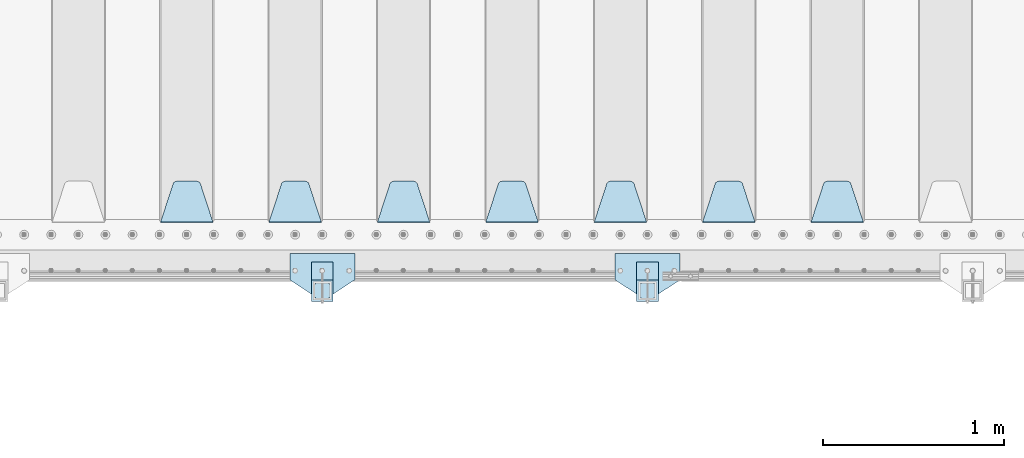
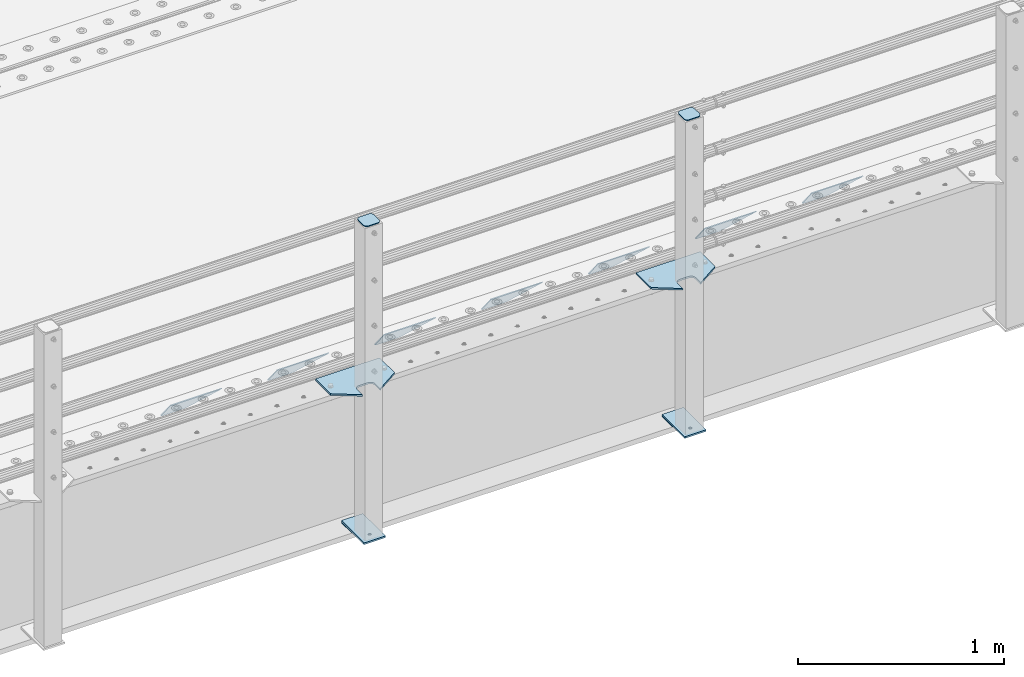
# One storey, part 176 of 208: 15 plates.
"""IFC2X3 building model written with IfcOpenShell, lengths in millimetres."""

from ifc_helpers import new_model, si_unit, frame, origin_with_axes, place, context, subcontext, project, spatial, faceted_brep, material, type_object, element, save


model = new_model("IFC2X3")

# Units and contexts
model_context = context("Model", 3, precision=1e-05, world=origin_with_axes())
body_context = subcontext(model_context, "Body", "Model", "MODEL_VIEW")
ifc_project = project(units=[si_unit("LENGTHUNIT", "METRE", prefix="MILLI"), si_unit("AREAUNIT", "SQUARE_METRE"), si_unit("VOLUMEUNIT", "CUBIC_METRE"), si_unit("MASSUNIT", "GRAM", prefix="KILO"), si_unit("TIMEUNIT", "SECOND"), si_unit("PLANEANGLEUNIT", "RADIAN"), si_unit("SOLIDANGLEUNIT", "STERADIAN"), si_unit("THERMODYNAMICTEMPERATUREUNIT", "DEGREE_CELSIUS"), si_unit("LUMINOUSINTENSITYUNIT", "LUMEN")], contexts=[model_context])

# Site, building, storey
site_placement = place(None, origin_with_axes())
site = spatial("IfcSite", under=ifc_project, at=site_placement, CompositionType="ELEMENT")
building_placement = place(site_placement, origin_with_axes())
building = spatial("IfcBuilding", under=site, at=building_placement, Name="Standard", CompositionType="ELEMENT")
storey_placement = place(building_placement, origin_with_axes())
storey = spatial("IfcBuildingStorey", under=building, at=storey_placement, Name="Undefined", CompositionType="ELEMENT", Elevation=0.0)

# Plates
ifc_material_1 = material(Name="STEEL/S355N")
plate_type_1 = type_object("IfcPlateType", PredefinedType="NOTDEFINED")
plate_1_placement = place(storey_placement, frame((-31705.0, 168.232233047019, -1.76776695296758), z_axis=(0.0, 0.707106781186547, -0.707106781186548), x_axis=(-1.0, 0.0, 0.0)))
element("IfcPlate", 1, at=plate_1_placement, inside=storey, type_object=plate_type_1, material=ifc_material_1, context=body_context, shape_type="Brep", body=[
    faceted_brep([(0.0, -2.5, 0.0), (69.345504679477, -2.5, 300.17173142483), (69.345504679477, 2.5, 300.17173142483), (0.0, 2.5, 0.0), (70.9274061199576, -2.5, 304.897442415399), (70.9274061199576, 2.5, 304.8974424154), (73.3818627772307, -2.5, 309.234538108527), (73.3818627772307, 2.5, 309.234538108527), (76.6187032999551, -2.5, 313.023683126103), (76.6187032999551, 2.5, 313.023683126103), (80.5190132704993, -2.5, 316.125672595371), (80.5190132704993, 2.5, 316.125672595371), (84.9395038596849, -2.5, 318.426546230476), (84.9395038596849, 2.50000000000091, 318.426546230476), (89.7177759439219, -2.5, 319.841774983275), (89.7177759439219, 2.50000000000091, 319.841774983275), (94.678286292652, -2.49999999999909, 320.319366455078), (94.678286292652, 2.5, 320.319366455078), (195.321713707348, -2.49999999999909, 320.319366455078), (195.321713707348, 2.5, 320.319366455078), (200.282224056078, -2.5, 319.841774983275), (200.282224056078, 2.5, 319.841774983274), (205.060496140315, -2.5, 318.426546230475), (205.060496140315, 2.5, 318.426546230475), (209.480986729501, -2.5, 316.125672595371), (209.480986729501, 2.50000000000091, 316.125672595371), (213.381296700045, -2.5, 313.023683126102), (213.381296700045, 2.5, 313.023683126102), (216.618137222769, -2.5, 309.234538108526), (216.618137222769, 2.5, 309.234538108527), (219.072593880042, -2.5, 304.897442415399), (219.072593880042, 2.5, 304.897442415399), (220.654495320523, -2.5, 300.17173142483), (220.654495320523, 2.5, 300.17173142483), (290.0, -2.5, 0.0), (290.0, 2.5, 0.0)], [[[0, 1, 2, 3]], [[1, 4, 5, 2]], [[4, 6, 7, 5]], [[6, 8, 9, 7]], [[8, 10, 11, 9]], [[10, 12, 13, 11]], [[12, 14, 15, 13]], [[14, 16, 17, 15]], [[16, 18, 19, 17]], [[18, 20, 21, 19]], [[20, 22, 23, 21]], [[22, 24, 25, 23]], [[24, 26, 27, 25]], [[26, 28, 29, 27]], [[28, 30, 31, 29]], [[30, 32, 33, 31]], [[32, 34, 35, 33]], [[34, 0, 3, 35]], [[5, 7, 9, 11, 13, 15, 17, 19, 21, 23, 25, 27, 29, 31, 33, 35, 3, 2]], [[34, 32, 30, 28, 26, 24, 22, 20, 18, 16, 14, 12, 10, 8, 6, 4, 1, 0]]]),
])
plate_2_placement = place(storey_placement, frame((-32305.0, 168.232233047023, -1.76776695296758), z_axis=(0.0, 0.707106781186547, -0.707106781186548), x_axis=(-1.0, 0.0, 0.0)))
element("IfcPlate", 2, at=plate_2_placement, inside=storey, type_object=plate_type_1, material=ifc_material_1, context=body_context, shape_type="Brep", body=[
    faceted_brep([(0.0, -2.5, 0.0), (69.345504679477, -2.5, 300.17173142483), (69.345504679477, 2.5, 300.17173142483), (0.0, 2.5, 0.0), (70.9274061199576, -2.5, 304.897442415399), (70.9274061199576, 2.5, 304.8974424154), (73.3818627772307, -2.5, 309.234538108527), (73.3818627772307, 2.5, 309.234538108527), (76.6187032999551, -2.5, 313.023683126103), (76.6187032999551, 2.5, 313.023683126103), (80.5190132704993, -2.5, 316.125672595371), (80.5190132704993, 2.5, 316.125672595371), (84.9395038596849, -2.5, 318.426546230476), (84.9395038596849, 2.50000000000091, 318.426546230476), (89.7177759439219, -2.5, 319.841774983275), (89.7177759439219, 2.50000000000091, 319.841774983275), (94.678286292652, -2.49999999999909, 320.319366455078), (94.678286292652, 2.5, 320.319366455078), (195.321713707348, -2.49999999999909, 320.319366455078), (195.321713707348, 2.5, 320.319366455078), (200.282224056078, -2.5, 319.841774983275), (200.282224056078, 2.5, 319.841774983274), (205.060496140315, -2.5, 318.426546230475), (205.060496140315, 2.5, 318.426546230475), (209.480986729501, -2.5, 316.125672595371), (209.480986729501, 2.50000000000091, 316.125672595371), (213.381296700045, -2.5, 313.023683126102), (213.381296700045, 2.5, 313.023683126102), (216.618137222769, -2.5, 309.234538108526), (216.618137222769, 2.5, 309.234538108527), (219.072593880042, -2.5, 304.897442415399), (219.072593880042, 2.5, 304.897442415399), (220.654495320523, -2.5, 300.17173142483), (220.654495320523, 2.5, 300.17173142483), (290.0, -2.5, 0.0), (290.0, 2.5, 0.0)], [[[0, 1, 2, 3]], [[1, 4, 5, 2]], [[4, 6, 7, 5]], [[6, 8, 9, 7]], [[8, 10, 11, 9]], [[10, 12, 13, 11]], [[12, 14, 15, 13]], [[14, 16, 17, 15]], [[16, 18, 19, 17]], [[18, 20, 21, 19]], [[20, 22, 23, 21]], [[22, 24, 25, 23]], [[24, 26, 27, 25]], [[26, 28, 29, 27]], [[28, 30, 31, 29]], [[30, 32, 33, 31]], [[32, 34, 35, 33]], [[34, 0, 3, 35]], [[5, 7, 9, 11, 13, 15, 17, 19, 21, 23, 25, 27, 29, 31, 33, 35, 3, 2]], [[34, 32, 30, 28, 26, 24, 22, 20, 18, 16, 14, 12, 10, 8, 6, 4, 1, 0]]]),
])
plate_3_placement = place(storey_placement, frame((-32905.0, 168.232233047023, -1.76776695296758), z_axis=(0.0, 0.707106781186547, -0.707106781186548), x_axis=(-1.0, 0.0, 0.0)))
element("IfcPlate", 3, at=plate_3_placement, inside=storey, type_object=plate_type_1, material=ifc_material_1, context=body_context, shape_type="Brep", body=[
    faceted_brep([(0.0, -2.5, 0.0), (69.345504679477, -2.5, 300.17173142483), (69.345504679477, 2.5, 300.17173142483), (0.0, 2.5, 0.0), (70.9274061199576, -2.5, 304.897442415399), (70.9274061199576, 2.5, 304.8974424154), (73.3818627772307, -2.5, 309.234538108527), (73.3818627772307, 2.5, 309.234538108527), (76.6187032999551, -2.5, 313.023683126103), (76.6187032999551, 2.5, 313.023683126103), (80.5190132704993, -2.5, 316.125672595371), (80.5190132704993, 2.5, 316.125672595371), (84.9395038596849, -2.5, 318.426546230476), (84.9395038596849, 2.50000000000091, 318.426546230476), (89.7177759439219, -2.5, 319.841774983275), (89.7177759439219, 2.50000000000091, 319.841774983275), (94.678286292652, -2.49999999999909, 320.319366455078), (94.678286292652, 2.5, 320.319366455078), (195.321713707348, -2.49999999999909, 320.319366455078), (195.321713707348, 2.5, 320.319366455078), (200.282224056078, -2.5, 319.841774983275), (200.282224056078, 2.5, 319.841774983274), (205.060496140315, -2.5, 318.426546230475), (205.060496140315, 2.5, 318.426546230475), (209.480986729501, -2.5, 316.125672595371), (209.480986729501, 2.50000000000091, 316.125672595371), (213.381296700045, -2.5, 313.023683126102), (213.381296700045, 2.5, 313.023683126102), (216.618137222769, -2.5, 309.234538108526), (216.618137222769, 2.5, 309.234538108527), (219.072593880042, -2.5, 304.897442415399), (219.072593880042, 2.5, 304.897442415399), (220.654495320523, -2.5, 300.17173142483), (220.654495320523, 2.5, 300.17173142483), (290.0, -2.5, 0.0), (290.0, 2.5, 0.0)], [[[0, 1, 2, 3]], [[1, 4, 5, 2]], [[4, 6, 7, 5]], [[6, 8, 9, 7]], [[8, 10, 11, 9]], [[10, 12, 13, 11]], [[12, 14, 15, 13]], [[14, 16, 17, 15]], [[16, 18, 19, 17]], [[18, 20, 21, 19]], [[20, 22, 23, 21]], [[22, 24, 25, 23]], [[24, 26, 27, 25]], [[26, 28, 29, 27]], [[28, 30, 31, 29]], [[30, 32, 33, 31]], [[32, 34, 35, 33]], [[34, 0, 3, 35]], [[5, 7, 9, 11, 13, 15, 17, 19, 21, 23, 25, 27, 29, 31, 33, 35, 3, 2]], [[34, 32, 30, 28, 26, 24, 22, 20, 18, 16, 14, 12, 10, 8, 6, 4, 1, 0]]]),
])
plate_4_placement = place(storey_placement, frame((-33505.0, 168.232233047023, -1.76776695296758), z_axis=(0.0, 0.707106781186547, -0.707106781186548), x_axis=(-1.0, 0.0, 0.0)))
element("IfcPlate", 4, at=plate_4_placement, inside=storey, type_object=plate_type_1, material=ifc_material_1, context=body_context, shape_type="Brep", body=[
    faceted_brep([(0.0, -2.5, 0.0), (69.345504679477, -2.5, 300.17173142483), (69.345504679477, 2.5, 300.17173142483), (0.0, 2.5, 0.0), (70.9274061199576, -2.5, 304.897442415399), (70.9274061199576, 2.5, 304.8974424154), (73.3818627772307, -2.5, 309.234538108527), (73.3818627772307, 2.5, 309.234538108527), (76.6187032999551, -2.5, 313.023683126103), (76.6187032999551, 2.5, 313.023683126103), (80.5190132704993, -2.5, 316.125672595371), (80.5190132704993, 2.5, 316.125672595371), (84.9395038596849, -2.5, 318.426546230476), (84.9395038596849, 2.50000000000091, 318.426546230476), (89.7177759439219, -2.5, 319.841774983275), (89.7177759439219, 2.50000000000091, 319.841774983275), (94.678286292652, -2.49999999999909, 320.319366455078), (94.678286292652, 2.5, 320.319366455078), (195.321713707348, -2.49999999999909, 320.319366455078), (195.321713707348, 2.5, 320.319366455078), (200.282224056078, -2.5, 319.841774983275), (200.282224056078, 2.5, 319.841774983274), (205.060496140315, -2.5, 318.426546230475), (205.060496140315, 2.5, 318.426546230475), (209.480986729501, -2.5, 316.125672595371), (209.480986729501, 2.50000000000091, 316.125672595371), (213.381296700045, -2.5, 313.023683126102), (213.381296700045, 2.5, 313.023683126102), (216.618137222769, -2.5, 309.234538108526), (216.618137222769, 2.5, 309.234538108527), (219.072593880042, -2.5, 304.897442415399), (219.072593880042, 2.5, 304.897442415399), (220.654495320523, -2.5, 300.17173142483), (220.654495320523, 2.5, 300.17173142483), (290.0, -2.5, 0.0), (290.0, 2.5, 0.0)], [[[0, 1, 2, 3]], [[1, 4, 5, 2]], [[4, 6, 7, 5]], [[6, 8, 9, 7]], [[8, 10, 11, 9]], [[10, 12, 13, 11]], [[12, 14, 15, 13]], [[14, 16, 17, 15]], [[16, 18, 19, 17]], [[18, 20, 21, 19]], [[20, 22, 23, 21]], [[22, 24, 25, 23]], [[24, 26, 27, 25]], [[26, 28, 29, 27]], [[28, 30, 31, 29]], [[30, 32, 33, 31]], [[32, 34, 35, 33]], [[34, 0, 3, 35]], [[5, 7, 9, 11, 13, 15, 17, 19, 21, 23, 25, 27, 29, 31, 33, 35, 3, 2]], [[34, 32, 30, 28, 26, 24, 22, 20, 18, 16, 14, 12, 10, 8, 6, 4, 1, 0]]]),
])
plate_5_placement = place(storey_placement, frame((-34105.0, 168.232233047023, -1.76776695296758), z_axis=(0.0, 0.707106781186547, -0.707106781186548), x_axis=(-1.0, 0.0, 0.0)))
element("IfcPlate", 5, at=plate_5_placement, inside=storey, type_object=plate_type_1, material=ifc_material_1, context=body_context, shape_type="Brep", body=[
    faceted_brep([(0.0, -2.5, 0.0), (69.345504679477, -2.5, 300.17173142483), (69.345504679477, 2.5, 300.17173142483), (0.0, 2.5, 0.0), (70.9274061199576, -2.5, 304.897442415399), (70.9274061199576, 2.5, 304.8974424154), (73.3818627772307, -2.5, 309.234538108527), (73.3818627772307, 2.5, 309.234538108527), (76.6187032999551, -2.5, 313.023683126103), (76.6187032999551, 2.5, 313.023683126103), (80.5190132704993, -2.5, 316.125672595371), (80.5190132704993, 2.5, 316.125672595371), (84.9395038596849, -2.5, 318.426546230476), (84.9395038596849, 2.50000000000091, 318.426546230476), (89.7177759439219, -2.5, 319.841774983275), (89.7177759439219, 2.50000000000091, 319.841774983275), (94.678286292652, -2.49999999999909, 320.319366455078), (94.678286292652, 2.5, 320.319366455078), (195.321713707348, -2.49999999999909, 320.319366455078), (195.321713707348, 2.5, 320.319366455078), (200.282224056078, -2.5, 319.841774983275), (200.282224056078, 2.5, 319.841774983274), (205.060496140315, -2.5, 318.426546230475), (205.060496140315, 2.5, 318.426546230475), (209.480986729501, -2.5, 316.125672595371), (209.480986729501, 2.50000000000091, 316.125672595371), (213.381296700045, -2.5, 313.023683126102), (213.381296700045, 2.5, 313.023683126102), (216.618137222769, -2.5, 309.234538108526), (216.618137222769, 2.5, 309.234538108527), (219.072593880042, -2.5, 304.897442415399), (219.072593880042, 2.5, 304.897442415399), (220.654495320523, -2.5, 300.17173142483), (220.654495320523, 2.5, 300.17173142483), (290.0, -2.5, 0.0), (290.0, 2.5, 0.0)], [[[0, 1, 2, 3]], [[1, 4, 5, 2]], [[4, 6, 7, 5]], [[6, 8, 9, 7]], [[8, 10, 11, 9]], [[10, 12, 13, 11]], [[12, 14, 15, 13]], [[14, 16, 17, 15]], [[16, 18, 19, 17]], [[18, 20, 21, 19]], [[20, 22, 23, 21]], [[22, 24, 25, 23]], [[24, 26, 27, 25]], [[26, 28, 29, 27]], [[28, 30, 31, 29]], [[30, 32, 33, 31]], [[32, 34, 35, 33]], [[34, 0, 3, 35]], [[5, 7, 9, 11, 13, 15, 17, 19, 21, 23, 25, 27, 29, 31, 33, 35, 3, 2]], [[34, 32, 30, 28, 26, 24, 22, 20, 18, 16, 14, 12, 10, 8, 6, 4, 1, 0]]]),
])
plate_6_placement = place(storey_placement, frame((-34705.0, 168.232233047023, -1.76776695296758), z_axis=(0.0, 0.707106781186547, -0.707106781186548), x_axis=(-1.0, 0.0, 0.0)))
element("IfcPlate", 6, at=plate_6_placement, inside=storey, type_object=plate_type_1, material=ifc_material_1, context=body_context, shape_type="Brep", body=[
    faceted_brep([(0.0, -2.5, 0.0), (69.345504679477, -2.5, 300.17173142483), (69.345504679477, 2.5, 300.17173142483), (0.0, 2.5, 0.0), (70.9274061199576, -2.5, 304.897442415399), (70.9274061199576, 2.5, 304.8974424154), (73.3818627772307, -2.5, 309.234538108527), (73.3818627772307, 2.5, 309.234538108527), (76.6187032999551, -2.5, 313.023683126103), (76.6187032999551, 2.5, 313.023683126103), (80.5190132704993, -2.5, 316.125672595371), (80.5190132704993, 2.5, 316.125672595371), (84.9395038596849, -2.5, 318.426546230476), (84.9395038596849, 2.50000000000091, 318.426546230476), (89.7177759439219, -2.5, 319.841774983275), (89.7177759439219, 2.50000000000091, 319.841774983275), (94.678286292652, -2.49999999999909, 320.319366455078), (94.678286292652, 2.5, 320.319366455078), (195.321713707348, -2.49999999999909, 320.319366455078), (195.321713707348, 2.5, 320.319366455078), (200.282224056078, -2.5, 319.841774983275), (200.282224056078, 2.5, 319.841774983274), (205.060496140315, -2.5, 318.426546230475), (205.060496140315, 2.5, 318.426546230475), (209.480986729501, -2.5, 316.125672595371), (209.480986729501, 2.50000000000091, 316.125672595371), (213.381296700045, -2.5, 313.023683126102), (213.381296700045, 2.5, 313.023683126102), (216.618137222769, -2.5, 309.234538108526), (216.618137222769, 2.5, 309.234538108527), (219.072593880042, -2.5, 304.897442415399), (219.072593880042, 2.5, 304.897442415399), (220.654495320523, -2.5, 300.17173142483), (220.654495320523, 2.5, 300.17173142483), (290.0, -2.5, 0.0), (290.0, 2.5, 0.0)], [[[0, 1, 2, 3]], [[1, 4, 5, 2]], [[4, 6, 7, 5]], [[6, 8, 9, 7]], [[8, 10, 11, 9]], [[10, 12, 13, 11]], [[12, 14, 15, 13]], [[14, 16, 17, 15]], [[16, 18, 19, 17]], [[18, 20, 21, 19]], [[20, 22, 23, 21]], [[22, 24, 25, 23]], [[24, 26, 27, 25]], [[26, 28, 29, 27]], [[28, 30, 31, 29]], [[30, 32, 33, 31]], [[32, 34, 35, 33]], [[34, 0, 3, 35]], [[5, 7, 9, 11, 13, 15, 17, 19, 21, 23, 25, 27, 29, 31, 33, 35, 3, 2]], [[34, 32, 30, 28, 26, 24, 22, 20, 18, 16, 14, 12, 10, 8, 6, 4, 1, 0]]]),
])
plate_7_placement = place(storey_placement, frame((-35305.0, 168.232233047023, -1.76776695296758), z_axis=(0.0, 0.707106781186547, -0.707106781186548), x_axis=(-1.0, 0.0, 0.0)))
element("IfcPlate", 7, at=plate_7_placement, inside=storey, type_object=plate_type_1, material=ifc_material_1, context=body_context, shape_type="Brep", body=[
    faceted_brep([(0.0, -2.5, 0.0), (69.345504679477, -2.5, 300.17173142483), (69.345504679477, 2.5, 300.17173142483), (0.0, 2.5, 0.0), (70.9274061199576, -2.5, 304.897442415399), (70.9274061199576, 2.5, 304.8974424154), (73.3818627772307, -2.5, 309.234538108527), (73.3818627772307, 2.5, 309.234538108527), (76.6187032999551, -2.5, 313.023683126103), (76.6187032999551, 2.5, 313.023683126103), (80.5190132704993, -2.5, 316.125672595371), (80.5190132704993, 2.5, 316.125672595371), (84.9395038596849, -2.5, 318.426546230476), (84.9395038596849, 2.50000000000091, 318.426546230476), (89.7177759439219, -2.5, 319.841774983275), (89.7177759439219, 2.50000000000091, 319.841774983275), (94.678286292652, -2.49999999999909, 320.319366455078), (94.678286292652, 2.5, 320.319366455078), (195.321713707348, -2.49999999999909, 320.319366455078), (195.321713707348, 2.5, 320.319366455078), (200.282224056078, -2.5, 319.841774983275), (200.282224056078, 2.5, 319.841774983274), (205.060496140315, -2.5, 318.426546230475), (205.060496140315, 2.5, 318.426546230475), (209.480986729501, -2.5, 316.125672595371), (209.480986729501, 2.50000000000091, 316.125672595371), (213.381296700045, -2.5, 313.023683126102), (213.381296700045, 2.5, 313.023683126102), (216.618137222769, -2.5, 309.234538108526), (216.618137222769, 2.5, 309.234538108527), (219.072593880042, -2.5, 304.897442415399), (219.072593880042, 2.5, 304.897442415399), (220.654495320523, -2.5, 300.17173142483), (220.654495320523, 2.5, 300.17173142483), (290.0, -2.5, 0.0), (290.0, 2.5, 0.0)], [[[0, 1, 2, 3]], [[1, 4, 5, 2]], [[4, 6, 7, 5]], [[6, 8, 9, 7]], [[8, 10, 11, 9]], [[10, 12, 13, 11]], [[12, 14, 15, 13]], [[14, 16, 17, 15]], [[16, 18, 19, 17]], [[18, 20, 21, 19]], [[20, 22, 23, 21]], [[22, 24, 25, 23]], [[24, 26, 27, 25]], [[26, 28, 29, 27]], [[28, 30, 31, 29]], [[30, 32, 33, 31]], [[32, 34, 35, 33]], [[34, 0, 3, 35]], [[5, 7, 9, 11, 13, 15, 17, 19, 21, 23, 25, 27, 29, 31, 33, 35, 3, 2]], [[34, 32, 30, 28, 26, 24, 22, 20, 18, 16, 14, 12, 10, 8, 6, 4, 1, 0]]]),
])
ifc_material_2 = material(Name="STEEL/S355J2")
plate_type_2 = type_object("IfcPlateType", PredefinedType="NOTDEFINED")
plate_8_placement = place(storey_placement, frame((-32720.0, -4.99999999999636, 5.00000000004911), z_axis=(0.0, -1.0, 0.0), x_axis=(-1.0, 0.0, 0.0)))
element("IfcPlate", 8, at=plate_8_placement, inside=storey, type_object=plate_type_2, material=ifc_material_2, context=body_context, shape_type="Brep", body=[
    faceted_brep([(0.0, -5.0, 0.0), (2.31396552408114e-06, -5.0, 145.0), (2.31396552408114e-06, 5.0, 145.0), (0.0, 5.0, 0.0), (130.0, -5.0, 230.0), (130.0, 5.0, 230.0), (130.0, -5.0, 180.0), (130.0, 5.0, 180.0), (130.48036798992, -5.0, 175.122741949597), (130.48036798992, 5.0, 175.122741949597), (131.903011687216, -5.0, 170.432914190873), (131.903011687216, 5.0, 170.432914190873), (134.213259692435, -5.0, 166.11074417451), (134.213259692435, 5.0, 166.11074417451), (137.322330470335, -5.0, 162.322330470336), (137.322330470335, 5.0, 162.322330470336), (141.110744174512, -5.0, 159.213259692437), (141.110744174512, 5.0, 159.213259692437), (145.432914190871, -5.0, 156.903011687218), (145.432914190871, 5.0, 156.903011687218), (150.122741949595, -5.0, 155.48036798992), (150.122741949595, 5.0, 155.48036798992), (155.0, -5.0, 155.0), (155.0, 5.0, 155.0), (205.0, -5.0, 155.0), (205.0, 5.0, 155.0), (209.877258050405, -5.0, 155.48036798992), (209.877258050405, 5.0, 155.48036798992), (214.567085809129, -5.0, 156.903011687218), (214.567085809129, 5.0, 156.903011687218), (218.889255825488, -5.0, 159.213259692437), (218.889255825488, 5.0, 159.213259692437), (222.677669529665, -5.0, 162.322330470336), (222.677669529665, 5.0, 162.322330470336), (225.786740307565, -5.0, 166.11074417451), (225.786740307565, 5.0, 166.11074417451), (228.096988312784, -5.0, 170.432914190873), (228.096988312784, 5.0, 170.432914190873), (229.51963201008, -5.0, 175.122741949597), (229.51963201008, 5.0, 175.122741949597), (230.0, -5.0, 180.0), (230.0, 5.0, 180.0), (230.0, -5.0, 230.0), (230.0, 5.0, 230.0), (360.0, -5.0, 145.0), (360.0, 5.0, 145.0), (360.0, -5.0, -7.27595761418343e-12), (360.0, 5.0, -7.27595761418343e-12)], [[[0, 1, 2, 3]], [[1, 4, 5, 2]], [[4, 6, 7, 5]], [[6, 8, 9, 7]], [[8, 10, 11, 9]], [[10, 12, 13, 11]], [[12, 14, 15, 13]], [[14, 16, 17, 15]], [[16, 18, 19, 17]], [[18, 20, 21, 19]], [[20, 22, 23, 21]], [[22, 24, 25, 23]], [[24, 26, 27, 25]], [[26, 28, 29, 27]], [[28, 30, 31, 29]], [[30, 32, 33, 31]], [[32, 34, 35, 33]], [[34, 36, 37, 35]], [[36, 38, 39, 37]], [[38, 40, 41, 39]], [[40, 42, 43, 41]], [[42, 44, 45, 43]], [[44, 46, 47, 45]], [[46, 0, 3, 47]], [[5, 7, 9, 11, 13, 15, 17, 19, 21, 23, 25, 27, 29, 31, 33, 35, 37, 39, 41, 43, 45, 47, 3, 2]], [[46, 44, 42, 40, 38, 36, 34, 32, 30, 28, 26, 24, 22, 20, 18, 16, 14, 12, 10, 8, 6, 4, 1, 0]]]),
])
plate_9_placement = place(storey_placement, frame((-34520.0, -4.99999999999636, 5.00000000004911), z_axis=(0.0, -1.0, 0.0), x_axis=(-1.0, 0.0, 0.0)))
element("IfcPlate", 9, at=plate_9_placement, inside=storey, type_object=plate_type_2, material=ifc_material_2, context=body_context, shape_type="Brep", body=[
    faceted_brep([(0.0, -5.0, 0.0), (2.31396552408114e-06, -5.0, 145.0), (2.31396552408114e-06, 5.0, 145.0), (0.0, 5.0, 0.0), (130.0, -5.0, 230.0), (130.0, 5.0, 230.0), (130.0, -5.0, 180.0), (130.0, 5.0, 180.0), (130.48036798992, -5.0, 175.122741949597), (130.48036798992, 5.0, 175.122741949597), (131.903011687216, -5.0, 170.432914190873), (131.903011687216, 5.0, 170.432914190873), (134.213259692435, -5.0, 166.11074417451), (134.213259692435, 5.0, 166.11074417451), (137.322330470335, -5.0, 162.322330470336), (137.322330470335, 5.0, 162.322330470336), (141.110744174512, -5.0, 159.213259692437), (141.110744174512, 5.0, 159.213259692437), (145.432914190871, -5.0, 156.903011687218), (145.432914190871, 5.0, 156.903011687218), (150.122741949595, -5.0, 155.48036798992), (150.122741949595, 5.0, 155.48036798992), (155.0, -5.0, 155.0), (155.0, 5.0, 155.0), (205.0, -5.0, 155.0), (205.0, 5.0, 155.0), (209.877258050405, -5.0, 155.48036798992), (209.877258050405, 5.0, 155.48036798992), (214.567085809129, -5.0, 156.903011687218), (214.567085809129, 5.0, 156.903011687218), (218.889255825488, -5.0, 159.213259692437), (218.889255825488, 5.0, 159.213259692437), (222.677669529665, -5.0, 162.322330470336), (222.677669529665, 5.0, 162.322330470336), (225.786740307565, -5.0, 166.11074417451), (225.786740307565, 5.0, 166.11074417451), (228.096988312784, -5.0, 170.432914190873), (228.096988312784, 5.0, 170.432914190873), (229.51963201008, -5.0, 175.122741949597), (229.51963201008, 5.0, 175.122741949597), (230.0, -5.0, 180.0), (230.0, 5.0, 180.0), (230.0, -5.0, 230.0), (230.0, 5.0, 230.0), (360.0, -5.0, 145.0), (360.0, 5.0, 145.0), (360.0, -5.0, -7.27595761418343e-12), (360.0, 5.0, -7.27595761418343e-12)], [[[0, 1, 2, 3]], [[1, 4, 5, 2]], [[4, 6, 7, 5]], [[6, 8, 9, 7]], [[8, 10, 11, 9]], [[10, 12, 13, 11]], [[12, 14, 15, 13]], [[14, 16, 17, 15]], [[16, 18, 19, 17]], [[18, 20, 21, 19]], [[20, 22, 23, 21]], [[22, 24, 25, 23]], [[24, 26, 27, 25]], [[26, 28, 29, 27]], [[28, 30, 31, 29]], [[30, 32, 33, 31]], [[32, 34, 35, 33]], [[34, 36, 37, 35]], [[36, 38, 39, 37]], [[38, 40, 41, 39]], [[40, 42, 43, 41]], [[42, 44, 45, 43]], [[44, 46, 47, 45]], [[46, 0, 3, 47]], [[5, 7, 9, 11, 13, 15, 17, 19, 21, 23, 25, 27, 29, 31, 33, 35, 37, 39, 41, 43, 45, 47, 3, 2]], [[46, 44, 42, 40, 38, 36, 34, 32, 30, 28, 26, 24, 22, 20, 18, 16, 14, 12, 10, 8, 6, 4, 1, 0]]]),
])
plate_type_3 = type_object("IfcPlateType", PredefinedType="NOTDEFINED")
for number, where, z_axis, x_axis in (
    (10, (-32840.0000000001, -50.0000000002074, -850.000000000002), (0.0, -1.0, 0.0), (-1.0, 0.0, 0.0)),
    (11, (-34640.0000000001, -50.0000000002074, -850.000000000002), (0.0, -1.0, 0.0), (-1.0, 0.0, 0.0)),
):
    element("IfcPlate", number, at=place(storey_placement, frame(where, z_axis=z_axis, x_axis=x_axis)), inside=storey, type_object=plate_type_3, material=ifc_material_2, context=body_context, shape_type="Brep", body=[
        faceted_brep([(53.6360389691836, -5.0, 176.36396103047), (53.6360389691836, 5.0, 176.36396103047), (59.9999999998618, 5.0, 178.999999999791), (59.9999999998618, -5.0, 178.999999999791), (66.3639610305399, 5.0, 176.36396103047), (66.3639610305399, -5.0, 176.36396103047), (68.9999999998618, 5.0, 169.999999999791), (68.9999999998618, -5.0, 169.999999999791), (66.3639610305399, 5.0, 163.636038969112), (66.3639610305399, -5.0, 163.636038969112), (59.9999999998618, 5.0, 160.999999999791), (59.9999999998618, -5.0, 160.999999999791), (53.6360389691836, 5.0, 163.636038969112), (53.6360389691836, -5.0, 163.636038969112), (50.9999999998618, 5.0, 169.999999999791), (50.9999999998618, -5.0, 169.999999999791), (120.0, -5.0, 0.0), (120.0, -5.0, 220.0), (0.0, -5.0, 220.0), (0.0, -5.0, 0.0), (0.0, 5.0, 0.0), (120.0, 5.0, 0.0), (120.0, 5.0, 220.0), (0.0, 5.0, 220.0)], [[[0, 1, 2, 3]], [[3, 2, 4, 5]], [[5, 4, 6, 7]], [[7, 6, 8, 9]], [[9, 8, 10, 11]], [[11, 10, 12, 13]], [[13, 12, 14, 15]], [[15, 14, 1, 0]], [[16, 17, 18, 19], [11, 13, 15, 0, 3, 5, 7, 9]], [[16, 19, 20, 21]], [[17, 16, 21, 22]], [[18, 17, 22, 23]], [[19, 18, 23, 20]], [[22, 21, 20, 23], [2, 1, 14, 12, 10, 8, 6, 4]]]),
    ])
plate_type_4 = type_object("IfcPlateType", PredefinedType="NOTDEFINED")
plate_10_placement = place(storey_placement, frame((-32944.0000000001, -166.000000000207, 1012.50000000001), z_axis=(0.0, -1.0, 0.0), x_axis=(1.0, 0.0, 0.0)))
element("IfcPlate", 12, at=plate_10_placement, inside=storey, type_object=plate_type_4, material=ifc_material_2, context=body_context, shape_type="Brep", body=[
    faceted_brep([(0.0, -2.5, 19.0), (0.0, -2.5, 69.0), (0.0, 2.5, 69.0), (0.0, 2.5, 19.0), (0.476369668544066, -2.5, 73.2278977451697), (0.476369668544066, 2.5, 73.2278977451697), (1.88159150985302, -2.5, 77.2437910432336), (1.88159150985302, 2.5, 77.2437910432336), (4.14520183310742, -2.5, 80.8463062353158), (4.14520183310742, 2.5, 80.8463062353158), (7.15369376468516, -2.5, 83.8547981668926), (7.15369376468516, 2.5, 83.8547981668926), (10.7562089567655, -2.5, 86.1184084901461), (10.7562089567655, 2.5, 86.1184084901461), (14.7721022548285, -2.5, 87.523630331455), (14.7721022548285, 2.5, 87.523630331455), (19.0, -2.5, 88.0), (19.0, 2.5, 88.0), (69.0, -2.5, 88.0), (69.0, 2.5, 88.0), (73.2278977451715, -2.5, 87.523630331455), (73.2278977451715, 2.5, 87.523630331455), (77.2437910432345, -2.5, 86.1184084901461), (77.2437910432345, 2.5, 86.1184084901461), (80.8463062353148, -2.5, 83.8547981668926), (80.8463062353148, 2.5, 83.8547981668926), (83.8547981668926, -2.5, 80.8463062353158), (83.8547981668926, 2.5, 80.8463062353158), (86.118408490147, -2.5, 77.2437910432336), (86.118408490147, 2.5, 77.2437910432336), (87.5236303314559, -2.5, 73.2278977451697), (87.5236303314559, 2.5, 73.2278977451697), (88.0, -2.5, 69.0), (88.0, 2.5, 69.0), (88.0, -2.5, 19.0), (88.0, 2.5, 19.0), (87.5236303314559, -2.5, 14.7721022548303), (87.5236303314559, 2.5, 14.7721022548303), (86.118408490147, -2.5, 10.7562089567664), (86.118408490147, 2.5, 10.7562089567664), (83.8547981668926, -2.5, 7.15369376468425), (83.8547981668926, 2.5, 7.15369376468425), (80.8463062353148, -2.5, 4.14520183310742), (80.8463062353148, 2.5, 4.14520183310742), (77.2437910432345, -2.5, 1.88159150985393), (77.2437910432345, 2.5, 1.88159150985393), (73.2278977451715, -2.5, 0.476369668544976), (73.2278977451715, 2.5, 0.476369668544976), (69.0, -2.5, 0.0), (69.0, 2.5, 0.0), (19.0, -2.5, 0.0), (19.0, 2.5, 0.0), (14.7721022548285, -2.5, 0.476369668544976), (14.7721022548285, 2.5, 0.476369668544976), (10.7562089567655, -2.5, 1.88159150985393), (10.7562089567655, 2.5, 1.88159150985393), (7.15369376468516, -2.5, 4.14520183310742), (7.15369376468516, 2.5, 4.14520183310742), (4.14520183310742, -2.5, 7.15369376468425), (4.14520183310742, 2.5, 7.15369376468425), (1.88159150985302, -2.5, 10.7562089567664), (1.88159150985302, 2.5, 10.7562089567664), (0.476369668544066, -2.5, 14.7721022548303), (0.476369668544066, 2.5, 14.7721022548303)], [[[0, 1, 2, 3]], [[1, 4, 5, 2]], [[4, 6, 7, 5]], [[6, 8, 9, 7]], [[8, 10, 11, 9]], [[10, 12, 13, 11]], [[12, 14, 15, 13]], [[14, 16, 17, 15]], [[16, 18, 19, 17]], [[18, 20, 21, 19]], [[20, 22, 23, 21]], [[22, 24, 25, 23]], [[24, 26, 27, 25]], [[26, 28, 29, 27]], [[28, 30, 31, 29]], [[30, 32, 33, 31]], [[32, 34, 35, 33]], [[34, 36, 37, 35]], [[36, 38, 39, 37]], [[38, 40, 41, 39]], [[40, 42, 43, 41]], [[42, 44, 45, 43]], [[44, 46, 47, 45]], [[46, 48, 49, 47]], [[48, 50, 51, 49]], [[50, 52, 53, 51]], [[52, 54, 55, 53]], [[54, 56, 57, 55]], [[56, 58, 59, 57]], [[58, 60, 61, 59]], [[60, 62, 63, 61]], [[62, 0, 3, 63]], [[5, 7, 9, 11, 13, 15, 17, 19, 21, 23, 25, 27, 29, 31, 33, 35, 37, 39, 41, 43, 45, 47, 49, 51, 53, 55, 57, 59, 61, 63, 3, 2]], [[62, 60, 58, 56, 54, 52, 50, 48, 46, 44, 42, 40, 38, 36, 34, 32, 30, 28, 26, 24, 22, 20, 18, 16, 14, 12, 10, 8, 6, 4, 1, 0]]]),
])
plate_11_placement = place(storey_placement, frame((-34744.0000000001, -166.000000000207, 1012.50000000001), z_axis=(0.0, -1.0, 0.0), x_axis=(1.0, 0.0, 0.0)))
element("IfcPlate", 13, at=plate_11_placement, inside=storey, type_object=plate_type_4, material=ifc_material_2, context=body_context, shape_type="Brep", body=[
    faceted_brep([(0.0, -2.5, 19.0), (0.0, -2.5, 69.0), (0.0, 2.5, 69.0), (0.0, 2.5, 19.0), (0.476369668544066, -2.5, 73.2278977451697), (0.476369668544066, 2.5, 73.2278977451697), (1.88159150985302, -2.5, 77.2437910432336), (1.88159150985302, 2.5, 77.2437910432336), (4.14520183310742, -2.5, 80.8463062353158), (4.14520183310742, 2.5, 80.8463062353158), (7.15369376468516, -2.5, 83.8547981668926), (7.15369376468516, 2.5, 83.8547981668926), (10.7562089567655, -2.5, 86.1184084901461), (10.7562089567655, 2.5, 86.1184084901461), (14.7721022548285, -2.5, 87.523630331455), (14.7721022548285, 2.5, 87.523630331455), (19.0, -2.5, 88.0), (19.0, 2.5, 88.0), (69.0, -2.5, 88.0), (69.0, 2.5, 88.0), (73.2278977451715, -2.5, 87.523630331455), (73.2278977451715, 2.5, 87.523630331455), (77.2437910432345, -2.5, 86.1184084901461), (77.2437910432345, 2.5, 86.1184084901461), (80.8463062353148, -2.5, 83.8547981668926), (80.8463062353148, 2.5, 83.8547981668926), (83.8547981668926, -2.5, 80.8463062353158), (83.8547981668926, 2.5, 80.8463062353158), (86.118408490147, -2.5, 77.2437910432336), (86.118408490147, 2.5, 77.2437910432336), (87.5236303314559, -2.5, 73.2278977451697), (87.5236303314559, 2.5, 73.2278977451697), (88.0, -2.5, 69.0), (88.0, 2.5, 69.0), (88.0, -2.5, 19.0), (88.0, 2.5, 19.0), (87.5236303314559, -2.5, 14.7721022548303), (87.5236303314559, 2.5, 14.7721022548303), (86.118408490147, -2.5, 10.7562089567664), (86.118408490147, 2.5, 10.7562089567664), (83.8547981668926, -2.5, 7.15369376468425), (83.8547981668926, 2.5, 7.15369376468425), (80.8463062353148, -2.5, 4.14520183310742), (80.8463062353148, 2.5, 4.14520183310742), (77.2437910432345, -2.5, 1.88159150985393), (77.2437910432345, 2.5, 1.88159150985393), (73.2278977451715, -2.5, 0.476369668544976), (73.2278977451715, 2.5, 0.476369668544976), (69.0, -2.5, 0.0), (69.0, 2.5, 0.0), (19.0, -2.5, 0.0), (19.0, 2.5, 0.0), (14.7721022548285, -2.5, 0.476369668544976), (14.7721022548285, 2.5, 0.476369668544976), (10.7562089567655, -2.5, 1.88159150985393), (10.7562089567655, 2.5, 1.88159150985393), (7.15369376468516, -2.5, 4.14520183310742), (7.15369376468516, 2.5, 4.14520183310742), (4.14520183310742, -2.5, 7.15369376468425), (4.14520183310742, 2.5, 7.15369376468425), (1.88159150985302, -2.5, 10.7562089567664), (1.88159150985302, 2.5, 10.7562089567664), (0.476369668544066, -2.5, 14.7721022548303), (0.476369668544066, 2.5, 14.7721022548303)], [[[0, 1, 2, 3]], [[1, 4, 5, 2]], [[4, 6, 7, 5]], [[6, 8, 9, 7]], [[8, 10, 11, 9]], [[10, 12, 13, 11]], [[12, 14, 15, 13]], [[14, 16, 17, 15]], [[16, 18, 19, 17]], [[18, 20, 21, 19]], [[20, 22, 23, 21]], [[22, 24, 25, 23]], [[24, 26, 27, 25]], [[26, 28, 29, 27]], [[28, 30, 31, 29]], [[30, 32, 33, 31]], [[32, 34, 35, 33]], [[34, 36, 37, 35]], [[36, 38, 39, 37]], [[38, 40, 41, 39]], [[40, 42, 43, 41]], [[42, 44, 45, 43]], [[44, 46, 47, 45]], [[46, 48, 49, 47]], [[48, 50, 51, 49]], [[50, 52, 53, 51]], [[52, 54, 55, 53]], [[54, 56, 57, 55]], [[56, 58, 59, 57]], [[58, 60, 61, 59]], [[60, 62, 63, 61]], [[62, 0, 3, 63]], [[5, 7, 9, 11, 13, 15, 17, 19, 21, 23, 25, 27, 29, 31, 33, 35, 37, 39, 41, 43, 45, 47, 49, 51, 53, 55, 57, 59, 61, 63, 3, 2]], [[62, 60, 58, 56, 54, 52, 50, 48, 46, 44, 42, 40, 38, 36, 34, 32, 30, 28, 26, 24, 22, 20, 18, 16, 14, 12, 10, 8, 6, 4, 1, 0]]]),
])
plate_type_5 = type_object("IfcPlateType", PredefinedType="NOTDEFINED")
for number, where, z_axis, x_axis in (
    (14, (-32840.0000000001, -50.0000000002074, -857.500000000002), (0.0, -1.0, 0.0), (-1.0, 0.0, 0.0)),
    (15, (-34640.0000000001, -50.0000000002074, -857.500000000002), (0.0, -1.0, 0.0), (-1.0, 0.0, 0.0)),
):
    element("IfcPlate", number, at=place(storey_placement, frame(where, z_axis=z_axis, x_axis=x_axis)), inside=storey, type_object=plate_type_5, material=ifc_material_2, context=body_context, shape_type="Brep", body=[
        faceted_brep([(0.0, -2.5, 0.0), (0.0, -2.5, 100.0), (0.0, 2.5, 100.0), (0.0, 2.5, 0.0), (120.0, -2.5, 100.0), (120.0, 2.5, 100.0), (120.0, -2.5, 0.0), (120.0, 2.5, 0.0)], [[[0, 1, 2, 3]], [[1, 4, 5, 2]], [[4, 6, 7, 5]], [[6, 0, 3, 7]], [[5, 7, 3, 2]], [[6, 4, 1, 0]]]),
    ])

save(model, "model.ifc")
